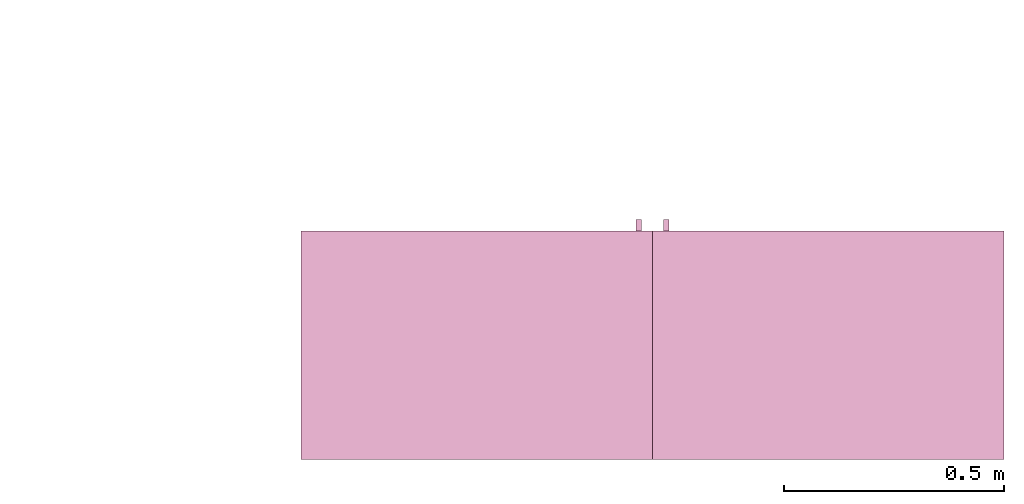
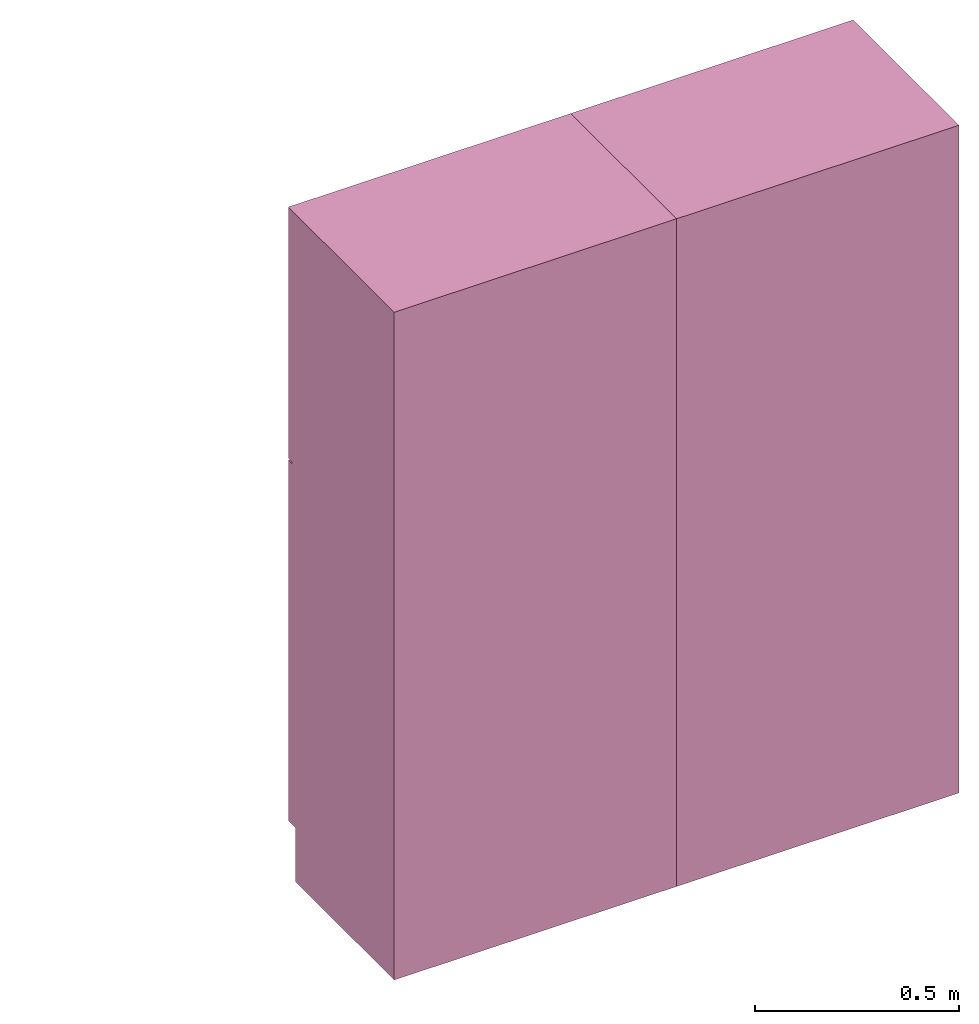
# One storey, part 2 of 3: 2 furnishings, 2 openings.
"""IFC2X3 building model written with IfcOpenShell, lengths in metres."""

from ifc_helpers import new_model, entity, si_unit, converted_unit, frame, origin, origin_with_axes, origin_2d_with_axis, place, context, project, spatial, rectangle, extrude, face_set, surface_model, source, transform, mapped, type_object, type_shapes, element, save


model = new_model("IFC2X3")

# Units and contexts
model_context = context("Model", 3, precision=1e-09, world=origin())
plan_context = context("Plan", 3, precision=1e-09, world=origin())
ifc_project = project(units=[si_unit("LENGTHUNIT", "METRE"), si_unit("AREAUNIT", "SQUARE_METRE"), si_unit("VOLUMEUNIT", "CUBIC_METRE"), converted_unit("PLANEANGLEUNIT", "DEGREE", entity("IfcRatioMeasure", 0.0174532925199433), si_unit("PLANEANGLEUNIT", "RADIAN"), dimensions=[0, 0, 0, 0, 0, 0, 0]), si_unit("TIMEUNIT", "SECOND")], contexts=[model_context, plan_context])

# Site, building, storey, space
site_placement = place(None, origin_with_axes())
site = spatial("IfcSite", under=ifc_project, at=site_placement, CompositionType="ELEMENT")
building_placement = place(None, origin_with_axes())
building = spatial("IfcBuilding", under=site, at=building_placement, CompositionType="ELEMENT")
storey_placement = place(None, frame((0.0, 0.0, 3.10000000000038), z_axis=(0.0, 0.0, 1.0), x_axis=(1.0, 0.0, 0.0)))
storey = spatial("IfcBuildingStorey", under=building, at=storey_placement, Name="Level 2", CompositionType="ELEMENT", Elevation=3.10000000000038)
space_placement = place(None, frame((0.0, 0.0, 3.10000000000038), z_axis=(0.0, 0.0, 1.0), x_axis=(1.0, 0.0, 0.0)))
space = spatial("IfcSpace", under=storey, at=space_placement, CompositionType="ELEMENT", InteriorOrExteriorSpace="INTERNAL")

# Furnishing, opening
furniture_type_1 = type_object("IfcFurnitureType", Name="800 mm", AssemblyPlace="NOTDEFINED")
shared_shape_1 = source(origin(), model_context, "Body", "SurfaceModel", [
    surface_model("IfcFaceBasedSurfaceModel", [(0.8, 0.0444499999999999, 0.161587499999842), (0.0, 0.0444500000000025, 0.161587499999842), (0.0, 0.0444500000000025, 2.0), (0.8, 0.0444499999999999, 2.0), (0.780949999999997, 0.04445, 1.98094999999995), (0.0190499999999982, 0.0444500000000025, 1.98094999999995), (0.0190499999999982, 0.0444500000000025, 0.180637499999843), (0.780949999999997, 0.04445, 0.180637499999843), (0.0, 0.545400000000002, 2.0), (0.800000000000001, 0.5454, 2.0), (0.800000000000003, 0.5454, 0.0), (0.0, 0.545400000000001, 0.0), (0.780949999999999, 0.5454, 1.98094999999995), (0.0190499999999998, 0.545400000000002, 1.98094999999995), (0.0190499999999998, 0.545400000000002, 0.180637499999843), (0.780949999999999, 0.5454, 0.180637499999843), (0.8, 0.0604000000000018, 0.161587499999842), (0.8, 0.0604000000000018, 0.0), (0.0, 0.0604000000000018, 0.0), (0.0, 0.0604000000000018, 0.161587499999832), (0.7746, 0.0, 1.37154803669582), (0.7746, 0.0, 1.26994803669581), (0.762067768369355, 0.0, 1.26994803669581), (0.762067768369355, 0.0, 1.37154803669582), (0.774599999999999, 0.0, 1.21914803669582), (0.774599999999999, 0.0, 1.11754803669582), (0.762067768369354, 0.0, 1.11754803669582), (0.762067768369354, 0.0, 1.21914803669582), (0.7746, 0.0254, 1.37154803669582), (0.7746, 0.0254, 1.26994803669581), (0.762067768369356, 0.0254000000000001, 1.26994803669581), (0.762067768369356, 0.0254000000000001, 1.37154803669582), (0.774599999999999, 0.0254, 1.21914803669582), (0.774599999999999, 0.0254, 1.11754803669582), (0.762067768369354, 0.0254000000000001, 1.11754803669582), (0.762067768369354, 0.0254000000000001, 1.21914803669582), (0.7365, 0.0381000000000001, 1.93649999999996), (0.7365, 0.0381000000000001, 1.30804803669582), (0.0635000000000013, 0.0381000000000023, 1.30804803669582), (0.0635000000000013, 0.0381000000000023, 1.93649999999996), (0.736499999999999, 0.0381000000000001, 1.18104803669581), (0.736499999999999, 0.0381000000000001, 0.22508749999984), (0.0635000000000007, 0.0381000000000023, 0.22508749999984), (0.0635000000000007, 0.0381000000000023, 1.18104803669581), (0.7365, 0.0444500000000001, 1.93649999999996), (0.7365, 0.0444500000000001, 1.30804803669582), (0.0635000000000013, 0.0444500000000023, 1.30804803669582), (0.0635000000000013, 0.0444500000000023, 1.93649999999996), (0.736499999999999, 0.0444500000000001, 1.18104803669581), (0.736499999999999, 0.0444500000000001, 0.22508749999984), (0.0635000000000007, 0.0444500000000023, 0.22508749999984), (0.0635000000000007, 0.0444500000000023, 1.18104803669581), (0.8, 0.0253999999999998, 2.0), (0.8, 0.0253999999999998, 1.24772303669581), (0.0, 0.0254000000000025, 1.24772303669581), (0.0, 0.0254000000000025, 2.0), (0.7365, 0.0254000000000001, 1.93649999999996), (0.0635000000000012, 0.0254000000000023, 1.93649999999996), (0.0635000000000012, 0.0254000000000023, 1.30804803669582), (0.7365, 0.0254000000000001, 1.30804803669582), (0.8, 0.0253999999999998, 0.161587499999821), (0.0, 0.0254000000000025, 0.161587499999821), (0.0, 0.0254000000000025, 1.24137303669581), (0.8, 0.0253999999999998, 1.24137303669581), (0.736499999999999, 0.0254000000000001, 1.18104803669582), (0.0635000000000007, 0.0254000000000023, 1.18104803669582), (0.0635000000000007, 0.0254000000000023, 0.22508749999984), (0.736499999999999, 0.0254000000000001, 0.22508749999984), (0.8, 0.0444499999999998, 2.0), (0.8, 0.0444499999999998, 1.24772303669581), (0.0, 0.0444500000000025, 1.24772303669581), (0.0, 0.0444500000000025, 2.0), (0.7365, 0.0444500000000001, 1.93649999999996), (0.0635000000000013, 0.0444500000000023, 1.93649999999996), (0.0635000000000013, 0.0444500000000023, 1.30804803669582), (0.7365, 0.0444500000000001, 1.30804803669582), (0.8, 0.0444499999999998, 0.161587499999821), (0.0, 0.0444500000000025, 0.161587499999821), (0.0, 0.0444500000000025, 1.24137303669581), (0.8, 0.0444499999999998, 1.24137303669581), (0.736499999999999, 0.0444500000000001, 1.18104803669582), (0.0635000000000007, 0.0444500000000023, 1.18104803669582), (0.0635000000000007, 0.0444500000000023, 0.22508749999984), (0.736499999999999, 0.0444500000000001, 0.22508749999984), (0.780949999999999, 0.526350000000001, 1.98094999999995), (0.780949999999999, 0.526350000000001, 0.180637499999846), (0.0190499999999999, 0.526350000000001, 0.180637499999846), (0.0190499999999998, 0.526350000000001, 1.98094999999995), (0.780949999999999, 0.545400000000001, 1.98094999999995), (0.780949999999999, 0.545400000000001, 0.180637499999846), (0.0190499999999998, 0.545400000000001, 0.180637499999846), (0.0190499999999998, 0.545400000000001, 1.98094999999995)], [face_set([[[0, 1, 2, 3], [4, 5, 6, 7]], [[8, 9, 10, 11], [12, 13, 14, 15]], [[3, 0, 16, 17, 10, 9]], [[2, 8, 9, 3]], [[1, 2, 8, 11, 18, 19]], [[0, 1, 19, 16]], [[7, 15, 12, 4]], [[6, 14, 15, 7]], [[5, 13, 14, 6]], [[4, 5, 13, 12]], [[10, 17, 18, 11]], [[18, 19, 16, 17]]]), face_set([[[20, 21, 22, 23]], [[24, 25, 26, 27]], [[28, 29, 30, 31]], [[32, 33, 34, 35]], [[23, 31, 28, 20]], [[22, 23, 31, 30]], [[21, 22, 30, 29]], [[20, 28, 29, 21]], [[27, 35, 32, 24]], [[26, 27, 35, 34]], [[25, 26, 34, 33]], [[24, 32, 33, 25]]]), face_set([[[36, 37, 38, 39]], [[40, 41, 42, 43]], [[44, 45, 46, 47]], [[48, 49, 50, 51]], [[39, 47, 44, 36]], [[38, 46, 47, 39]], [[37, 38, 46, 45]], [[36, 37, 45, 44]], [[43, 51, 48, 40]], [[42, 50, 51, 43]], [[41, 42, 50, 49]], [[40, 41, 49, 48]]]), face_set([[[52, 53, 54, 55], [56, 57, 58, 59]], [[60, 61, 62, 63], [64, 65, 66, 67]], [[68, 69, 70, 71], [72, 73, 74, 75]], [[76, 77, 78, 79], [80, 81, 82, 83]], [[55, 71, 68, 52]], [[54, 55, 71, 70]], [[53, 54, 70, 69]], [[52, 53, 69, 68]], [[63, 60, 76, 79]], [[62, 78, 79, 63]], [[61, 62, 78, 77]], [[60, 61, 77, 76]], [[59, 75, 72, 56]], [[58, 74, 75, 59]], [[57, 58, 74, 73]], [[56, 57, 73, 72]], [[67, 83, 80, 64]], [[66, 82, 83, 67]], [[65, 66, 82, 81]], [[64, 65, 81, 80]]]), face_set([[[84, 85, 86, 87]], [[88, 89, 90, 91]], [[87, 91, 88, 84]], [[86, 87, 91, 90]], [[85, 86, 90, 89]], [[84, 85, 89, 88]]])]),
])
type_shapes(furniture_type_1, [shared_shape_1])
furnishing_1_placement = place(None, frame((4.11699999999999, -6.1206, 3.10000000000038), z_axis=(0.0, 0.0, 1.0), x_axis=(-1.0, 0.0, 0.0)))
furnishing_1 = element("IfcFurnishingElement", 1, at=furnishing_1_placement, inside=space, type_object=furniture_type_1, context=model_context, shape_type="MappedRepresentation", body=[
    mapped(shared_shape_1, transform((0.0, 0.0, 0.0), scale=1.0)),
])
placement_1 = place(None, origin())
placement_2 = place(placement_1, origin())
placement_3 = place(placement_2, frame((0.0, 0.0, 3.10000000000038)))
placement_4 = place(placement_3, origin())
opening_1_placement = place(placement_4, frame((4.11699999999999, -6.1206, 0.0), z_axis=(0.0, 0.0, 1.0), x_axis=(-1.0, 0.0, 0.0)))
element("IfcOpeningElement", 2, at=opening_1_placement, cuts=furnishing_1, ObjectType="Opening", context=model_context, shape_type="SweptSolid", body=[
    extrude(rectangle(XDim=1.80031250000011, YDim=0.761899999999999, at=origin_2d_with_axis()), frame((-0.0187377049180267, 0.50095, -2.01920625000048), z_axis=(0.0, -1.0, 0.0), x_axis=(0.0, 0.0, -1.0)), (0.0, 0.0, 1.0), 0.50095),
])

furniture_type_2 = type_object("IfcFurnitureType", Name="800 mm", AssemblyPlace="NOTDEFINED")
shared_shape_2 = source(origin(), model_context, "Body", "SurfaceModel", [
    surface_model("IfcFaceBasedSurfaceModel", [(0.8, 0.500950000000002, 0.161587499999842), (0.8, 0.500950000000002, 2.0), (0.0, 0.50095, 2.0), (0.0, 0.50095, 0.161587499999842), (0.780949999999997, 0.500950000000002, 1.98094999999995), (0.780949999999997, 0.500950000000002, 0.180637499999843), (0.0190499999999982, 0.50095, 0.180637499999843), (0.0190499999999982, 0.50095, 1.98094999999995), (0.0, 0.0, 2.0), (0.0, 0.0, 0.0), (0.800000000000003, 0.0, 0.0), (0.800000000000001, 0.0, 2.0), (0.780949999999999, 0.0, 1.98094999999995), (0.780949999999999, 0.0, 0.180637499999843), (0.0190499999999998, 0.0, 0.180637499999843), (0.0190499999999998, 0.0, 1.98094999999995), (0.800000000000003, 0.485, 0.0), (0.8, 0.485, 0.161587499999832), (0.0, 0.485, 0.0), (0.0, 0.485, 0.161587499999842), (0.7746, 0.545400000000002, 1.37154803669582), (0.762067768369355, 0.545400000000002, 1.37154803669582), (0.762067768369355, 0.545400000000002, 1.26994803669581), (0.7746, 0.545400000000002, 1.26994803669581), (0.774599999999999, 0.545400000000002, 1.21914803669582), (0.762067768369354, 0.545400000000002, 1.21914803669582), (0.762067768369354, 0.545400000000002, 1.11754803669582), (0.774599999999999, 0.545400000000002, 1.11754803669582), (0.7746, 0.520000000000002, 1.37154803669582), (0.762067768369356, 0.520000000000002, 1.37154803669582), (0.762067768369356, 0.520000000000002, 1.26994803669581), (0.7746, 0.520000000000002, 1.26994803669581), (0.774599999999999, 0.520000000000002, 1.21914803669582), (0.762067768369354, 0.520000000000002, 1.21914803669582), (0.762067768369354, 0.520000000000002, 1.11754803669582), (0.774599999999999, 0.520000000000002, 1.11754803669582), (0.7365, 0.507300000000002, 1.93649999999996), (0.0635000000000013, 0.5073, 1.93649999999996), (0.0635000000000013, 0.5073, 1.30804803669582), (0.7365, 0.507300000000002, 1.30804803669582), (0.736499999999999, 0.507300000000002, 1.18104803669581), (0.0635000000000007, 0.5073, 1.18104803669581), (0.0635000000000007, 0.5073, 0.22508749999984), (0.736499999999999, 0.507300000000002, 0.22508749999984), (0.7365, 0.500950000000002, 1.93649999999996), (0.0635000000000013, 0.50095, 1.93649999999996), (0.0635000000000013, 0.50095, 1.30804803669582), (0.7365, 0.500950000000002, 1.30804803669582), (0.736499999999999, 0.500950000000002, 1.18104803669581), (0.0635000000000007, 0.50095, 1.18104803669581), (0.0635000000000007, 0.50095, 0.22508749999984), (0.736499999999999, 0.500950000000002, 0.22508749999984), (0.8, 0.520000000000002, 2.0), (0.0, 0.52, 2.0), (0.0, 0.52, 1.24772303669581), (0.8, 0.520000000000002, 1.24772303669581), (0.7365, 0.520000000000002, 1.93649999999996), (0.7365, 0.520000000000002, 1.30804803669582), (0.0635000000000012, 0.52, 1.30804803669582), (0.0635000000000012, 0.52, 1.93649999999996), (0.8, 0.520000000000002, 0.161587499999821), (0.8, 0.520000000000002, 1.24137303669581), (0.0, 0.52, 1.24137303669581), (0.0, 0.52, 0.161587499999821), (0.736499999999999, 0.520000000000002, 1.18104803669582), (0.736499999999999, 0.520000000000002, 0.22508749999984), (0.0635000000000007, 0.52, 0.22508749999984), (0.0635000000000007, 0.52, 1.18104803669582), (0.8, 0.500950000000002, 2.0), (0.0, 0.50095, 2.0), (0.0, 0.50095, 1.24772303669581), (0.8, 0.500950000000002, 1.24772303669581), (0.7365, 0.500950000000002, 1.93649999999996), (0.7365, 0.500950000000002, 1.30804803669582), (0.0635000000000013, 0.50095, 1.30804803669582), (0.0635000000000013, 0.50095, 1.93649999999996), (0.8, 0.500950000000002, 0.161587499999821), (0.8, 0.500950000000002, 1.24137303669581), (0.0, 0.50095, 1.24137303669581), (0.0, 0.50095, 0.161587499999821), (0.736499999999999, 0.500950000000002, 1.18104803669582), (0.736499999999999, 0.500950000000002, 0.22508749999984), (0.0635000000000007, 0.50095, 0.22508749999984), (0.0635000000000007, 0.50095, 1.18104803669582), (0.780949999999999, 0.0190500000000013, 1.98094999999995), (0.0190499999999998, 0.0190500000000013, 1.98094999999995), (0.0190499999999998, 0.0190500000000013, 0.180637499999846), (0.780949999999999, 0.0190500000000013, 0.180637499999846), (0.780949999999999, 0.0, 1.98094999999995), (0.0190499999999998, 0.0, 1.98094999999995), (0.0190499999999999, 0.0, 0.180637499999846), (0.780949999999999, 0.0, 0.180637499999846)], [face_set([[[0, 1, 2, 3], [4, 5, 6, 7]], [[8, 9, 10, 11], [12, 13, 14, 15]], [[1, 11, 10, 16, 17, 0]], [[2, 1, 11, 8]], [[3, 2, 8, 9, 18, 19]], [[0, 17, 19, 3]], [[5, 4, 12, 13]], [[6, 5, 13, 14]], [[7, 6, 14, 15]], [[4, 12, 15, 7]], [[10, 9, 18, 16]], [[18, 16, 17, 19]]]), face_set([[[20, 21, 22, 23]], [[24, 25, 26, 27]], [[28, 29, 30, 31]], [[32, 33, 34, 35]], [[21, 20, 28, 29]], [[22, 30, 29, 21]], [[23, 31, 30, 22]], [[20, 23, 31, 28]], [[25, 24, 32, 33]], [[26, 34, 33, 25]], [[27, 35, 34, 26]], [[24, 27, 35, 32]]]), face_set([[[36, 37, 38, 39]], [[40, 41, 42, 43]], [[44, 45, 46, 47]], [[48, 49, 50, 51]], [[37, 36, 44, 45]], [[38, 37, 45, 46]], [[39, 47, 46, 38]], [[36, 44, 47, 39]], [[41, 40, 48, 49]], [[42, 41, 49, 50]], [[43, 51, 50, 42]], [[40, 48, 51, 43]]]), face_set([[[52, 53, 54, 55], [56, 57, 58, 59]], [[60, 61, 62, 63], [64, 65, 66, 67]], [[68, 69, 70, 71], [72, 73, 74, 75]], [[76, 77, 78, 79], [80, 81, 82, 83]], [[53, 52, 68, 69]], [[54, 70, 69, 53]], [[55, 71, 70, 54]], [[52, 68, 71, 55]], [[61, 77, 76, 60]], [[62, 61, 77, 78]], [[63, 79, 78, 62]], [[60, 76, 79, 63]], [[57, 56, 72, 73]], [[58, 57, 73, 74]], [[59, 75, 74, 58]], [[56, 72, 75, 59]], [[65, 64, 80, 81]], [[66, 65, 81, 82]], [[67, 83, 82, 66]], [[64, 80, 83, 67]]]), face_set([[[84, 85, 86, 87]], [[88, 89, 90, 91]], [[85, 84, 88, 89]], [[86, 90, 89, 85]], [[87, 91, 90, 86]], [[84, 88, 91, 87]]])]),
])
type_shapes(furniture_type_2, [shared_shape_2])
furnishing_2_placement = place(None, frame((2.51699999999999, -6.66599999999999, 3.10000000000038), z_axis=(0.0, 0.0, 1.0), x_axis=(1.0, 0.0, 0.0)))
furnishing_2 = element("IfcFurnishingElement", 3, at=furnishing_2_placement, inside=space, type_object=furniture_type_2, context=model_context, shape_type="MappedRepresentation", body=[
    mapped(shared_shape_2, transform((0.0, 0.0, 0.0), scale=1.0)),
])
opening_2_placement = place(placement_4, frame((2.51699999999999, -6.66599999999999, 0.0)))
element("IfcOpeningElement", 4, at=opening_2_placement, cuts=furnishing_2, ObjectType="Opening", context=model_context, shape_type="SweptSolid", body=[
    extrude(rectangle(XDim=1.80031250000011, YDim=0.761899999999999, at=origin_2d_with_axis()), frame((0.0187377049180251, 0.0, -2.01920625000048), z_axis=(0.0, 1.0, 0.0), x_axis=(0.0, 0.0, -1.0)), (0.0, 0.0, 1.0), 0.50095),
])

save(model, "model.ifc")
